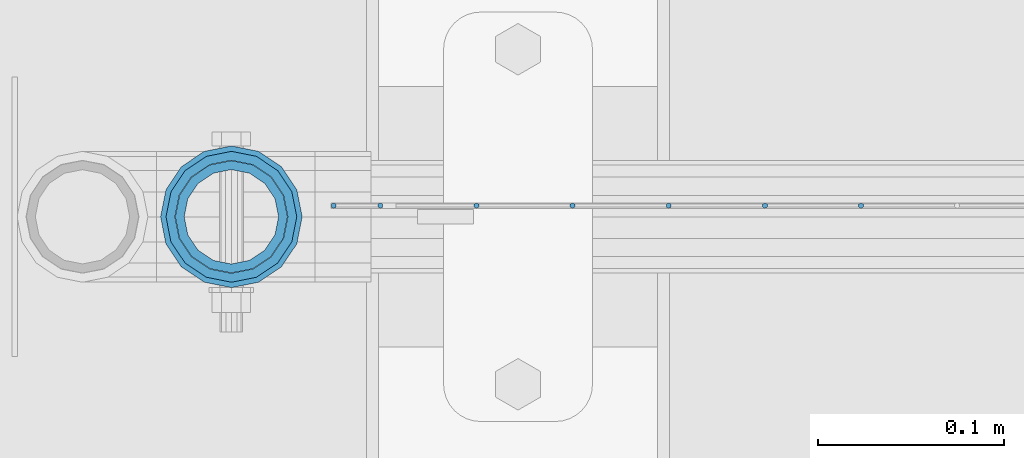
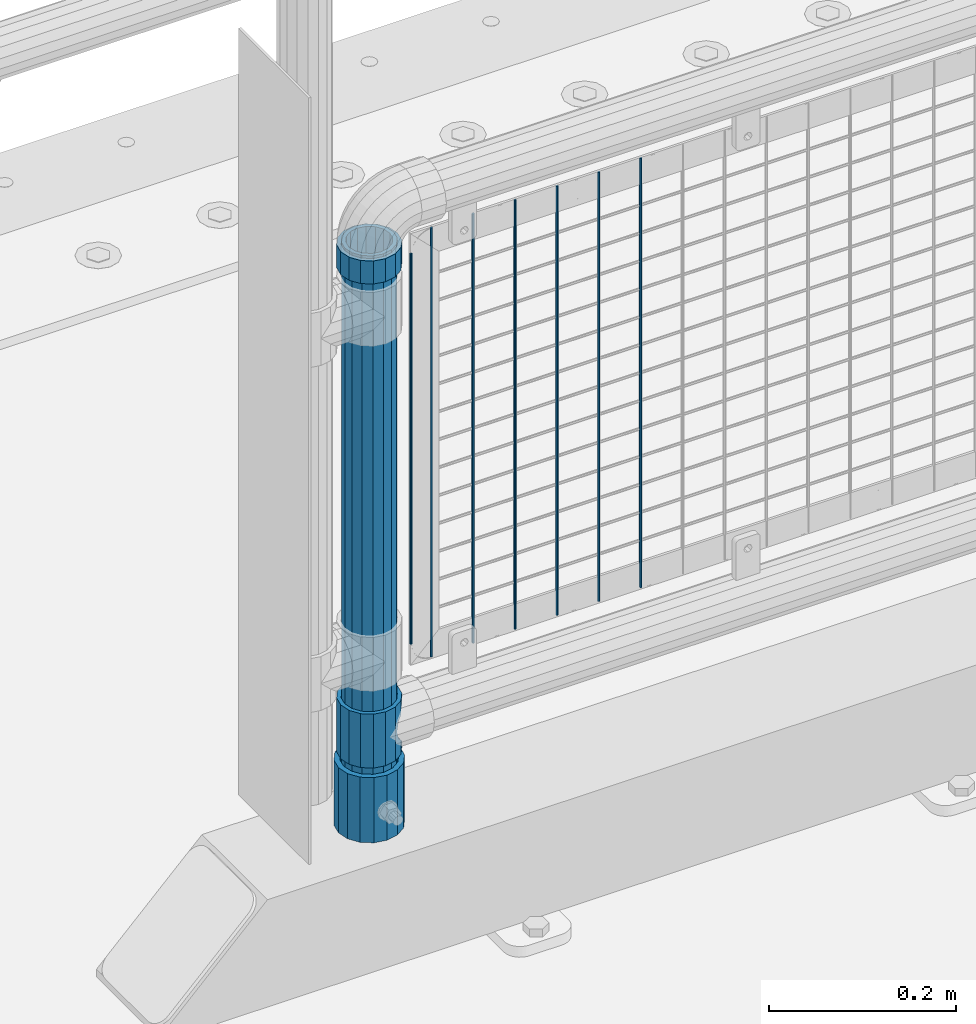
# One storey, part 63 of 219: 11 columns.
"""IFC2X3 building model written with IfcOpenShell, lengths in millimetres."""

from ifc_helpers import new_model, si_unit, frame, origin_with_axes, place, context, subcontext, project, spatial, faceted_brep, material, type_object, element, save


model = new_model("IFC2X3")

# Units and contexts
model_context = context("Model", 3, precision=1e-05, world=origin_with_axes())
body_context = subcontext(model_context, "Body", "Model", "MODEL_VIEW")
ifc_project = project(units=[si_unit("LENGTHUNIT", "METRE", prefix="MILLI"), si_unit("AREAUNIT", "SQUARE_METRE"), si_unit("VOLUMEUNIT", "CUBIC_METRE"), si_unit("MASSUNIT", "GRAM", prefix="KILO"), si_unit("TIMEUNIT", "SECOND"), si_unit("PLANEANGLEUNIT", "RADIAN"), si_unit("SOLIDANGLEUNIT", "STERADIAN"), si_unit("THERMODYNAMICTEMPERATUREUNIT", "DEGREE_CELSIUS"), si_unit("LUMINOUSINTENSITYUNIT", "LUMEN")], contexts=[model_context])

# Site, building, storey
site_placement = place(None, origin_with_axes())
site = spatial("IfcSite", under=ifc_project, at=site_placement, CompositionType="ELEMENT")
building_placement = place(site_placement, origin_with_axes())
building = spatial("IfcBuilding", under=site, at=building_placement, Name="Standard", CompositionType="ELEMENT")
storey_placement = place(building_placement, origin_with_axes())
storey = spatial("IfcBuildingStorey", under=building, at=storey_placement, Name="Undefined", CompositionType="ELEMENT", Elevation=0.0)

# Columns
ifc_material_1 = material(Name="Misc_Undefined")
column_type_1 = type_object("IfcColumnType", PredefinedType="NOTDEFINED")
column_1_placement = place(storey_placement, frame((621.0, 31664.5, 263.52), z_axis=(-1.0, 0.0, 0.0), x_axis=(0.0, 0.0, 1.0)))
element("IfcColumn", 1, at=column_1_placement, inside=storey, type_object=column_type_1, material=ifc_material_1, context=body_context, shape_type="Brep", body=[
    faceted_brep([(56.6106908090114, 21.46069080901, -21.4606908090118), (56.6106908090114, 21.46069080901, -27.1226768591096), (61.9623795176703, 13.4513226476338, -32.4743655677721), (63.1897438117172, 11.614442172282, -32.8397438117172), (63.1897438117172, 11.614442172282, -28.0397438117179), (46.7644421722801, 28.0397438117179, -11.6144421722802), (46.7644421722801, 28.0397438117179, -20.0882031229849), (51.5310424080006, 24.8548033587067, -24.8548033587067), (35.1499999999996, 30.35, 0.0), (35.1499999999996, 30.3499999999985, -16.6306603983739), (23.5355578277192, 28.0397438117179, -11.6144421722802), (23.5355578277192, 28.0397438117179, -20.0882031229849), (13.6893091909879, 21.46069080901, -21.4606908090118), (13.6893091909879, 21.46069080901, -27.1226768591096), (18.7689575919987, 24.8548033587067, -24.8548033587067), (7.11025618828211, 11.614442172282, -28.0397438117179), (7.11025618828211, 11.614442172282, -32.8397438117172), (8.33762048232455, 13.4513226476338, -32.4743655677721), (4.79999999999961, 0.0, -30.3500000000004), (4.79999999999961, 0.0, -35.1499999999996), (7.11025618828211, -11.614442172282, -28.0397438117179), (7.11025618828211, -11.614442172282, -32.839743811719), (13.6893091909879, -21.46069080901, -21.4606908090118), (13.6893091909879, -21.46069080901, -27.1226768591077), (8.33762048232455, -13.4513226476338, -32.4743655677721), (23.5355578277191, -28.0397438117179, -11.6144421722802), (23.5355578277191, -28.0397438117179, -20.0882031229739), (18.7689575919921, -24.8548033587067, -24.8548033587067), (35.1499999999996, -30.35, 0.0), (35.1499999999996, -30.3499999999985, -16.6306603983649), (46.7644421722801, -28.0397438117179, -11.6144421722802), (46.7644421722801, -28.0397438117179, -20.0882031229739), (56.6106908090114, -21.46069080901, -21.4606908090118), (56.6106908090114, -21.46069080901, -27.1226768591077), (51.5310424080006, -24.8548033587067, -24.8548033587067), (63.1897438117172, -11.614442172282, -28.0397438117179), (63.1897438117172, -11.614442172282, -32.839743811719), (61.9623795176747, -13.4513226476338, -32.4743655677721), (65.4999999999997, 0.0, -30.3500000000004), (65.4999999999997, 0.0, -35.1499999999996), (70.2999999999993, -11.614442172282, -28.0397438117179), (70.2999999999993, 0.0, -30.3500000000004), (70.2999999999993, -21.46069080901, -21.4606908090118), (70.2999999999993, -28.0397438117179, -11.6144421722802), (70.2999999999993, -30.3499999999985, 0.0), (0.0, -28.0397438117179, -11.6144421722802), (0.0, -30.3499999999985, 0.0), (0.0, -21.46069080901, -21.4606908090118), (0.0, -11.614442172282, -28.0397438117179), (0.0, 0.0, -30.3500000000004), (0.0, 11.614442172282, -28.0397438117179), (0.0, 21.46069080901, -21.4606908090118), (0.0, 28.0397438117179, -11.6144421722802), (0.0, 30.3499999999985, 0.0), (0.0, -24.8548033587067, -24.8548033587067), (0.0, -13.4513226476338, -32.4743655677721), (0.0, 0.0, -35.1500000000015), (0.0, 13.4513226476338, -32.4743655677721), (0.0, 24.8548033587067, -24.8548033587067), (0.0, -32.4743655677703, 13.4513226476338), (0.0, -35.1500000000015, 0.0), (70.2999999999993, -35.1500000000015, 0.0), (70.2999999999993, -32.4743655677703, 13.4513226476338), (0.0, -24.8548033587067, 24.8548033587067), (70.2999999999993, -24.8548033587067, 24.8548033587067), (0.0, -13.4513226476338, 32.4743655677721), (70.2999999999993, -13.4513226476338, 32.4743655677721), (0.0, 0.0, 35.1500000000015), (70.2999999999993, 0.0, 35.1499999999996), (0.0, 13.4513226476338, 32.4743655677721), (70.2999999999993, 13.4513226476338, 32.4743655677721), (0.0, 24.8548033587067, 24.8548033587067), (70.2999999999993, 24.8548033587067, 24.8548033587067), (0.0, 32.4743655677703, 13.4513226476338), (70.2999999999993, 32.4743655677703, 13.4513226476338), (0.0, 35.1500000000015, 0.0), (70.2999999999993, 35.1500000000015, 0.0), (0.0, 32.4743655677703, -13.4513226476338), (70.2999999999993, 32.4743655677703, -13.4513226476338), (70.2999999999993, 24.8548033587067, -24.8548033587067), (70.2999999999993, 13.4513226476338, -32.4743655677721), (70.2999999999993, 0.0, -35.1499999999996), (70.2999999999993, -13.4513226476338, -32.4743655677721), (70.2999999999993, -24.8548033587067, -24.8548033587067), (70.2999999999993, -32.4743655677703, -13.4513226476338), (0.0, -32.4743655677703, -13.4513226476338), (0.0, 28.0397438117179, 11.6144421722802), (0.0, 21.46069080901, 21.4606908090118), (0.0, 11.614442172282, 28.0397438117179), (0.0, 0.0, 30.3500000000004), (0.0, -11.614442172282, 28.0397438117179), (0.0, -21.46069080901, 21.4606908090118), (0.0, -28.0397438117179, 11.6144421722802), (70.2999999999993, 28.0397438117179, 11.6144421722802), (70.2999999999993, 21.46069080901, 21.4606908090118), (70.2999999999993, 11.614442172282, 28.0397438117179), (70.2999999999993, 0.0, 30.3500000000004), (70.2999999999993, -11.614442172282, 28.0397438117179), (70.2999999999993, -21.46069080901, 21.4606908090118), (70.2999999999993, -28.0397438117179, 11.6144421722802), (70.2999999999993, 30.3499999999985, 0.0), (70.2999999999993, 28.0397438117179, -11.6144421722802), (70.2999999999993, 21.46069080901, -21.4606908090118), (70.2999999999993, 11.614442172282, -28.0397438117179)], [[[0, 1, 2, 3, 4]], [[5, 6, 7, 1, 0]], [[8, 9, 6, 5]], [[10, 11, 9, 8]], [[12, 13, 14, 11, 10]], [[15, 16, 17, 13, 12]], [[18, 19, 16, 15]], [[20, 21, 19, 18]], [[22, 23, 24, 21, 20]], [[25, 26, 27, 23, 22]], [[28, 29, 26, 25]], [[30, 31, 29, 28]], [[32, 33, 34, 31, 30]], [[35, 36, 37, 33, 32]], [[38, 39, 36, 35]], [[4, 3, 39, 38]], [[40, 41, 38, 35]], [[42, 40, 35, 32]], [[43, 42, 32, 30]], [[44, 43, 30, 28]], [[45, 46, 28, 25]], [[47, 45, 25, 22]], [[48, 47, 22, 20]], [[49, 48, 20, 18]], [[50, 49, 18, 15]], [[51, 50, 15, 12]], [[52, 51, 12, 10]], [[53, 52, 10, 8]], [[54, 55, 24, 23, 27]], [[55, 56, 19, 21, 24]], [[19, 56, 57, 17, 16]], [[17, 57, 58, 14, 13]], [[59, 60, 61, 62]], [[63, 59, 62, 64]], [[65, 63, 64, 66]], [[67, 65, 66, 68]], [[69, 67, 68, 70]], [[71, 69, 70, 72]], [[73, 71, 72, 74]], [[75, 73, 74, 76]], [[77, 75, 76, 78]], [[14, 58, 77, 78, 79, 7, 6, 9, 11]], [[79, 80, 2, 1, 7]], [[80, 81, 39, 3, 2]], [[37, 82, 83, 34, 33]], [[39, 81, 82, 37, 36]], [[34, 83, 84, 85, 54, 27, 26, 29, 31]], [[60, 85, 84, 61]], [[59, 63, 65, 67, 69, 71, 73, 75, 77, 58, 57, 56, 55, 54, 85, 60], [45, 47, 48, 49, 50, 51, 52, 53, 86, 87, 88, 89, 90, 91, 92, 46]], [[87, 86, 93, 94]], [[88, 87, 94, 95]], [[89, 88, 95, 96]], [[90, 89, 96, 97]], [[91, 90, 97, 98]], [[92, 91, 98, 99]], [[28, 46, 92, 99, 44]], [[83, 82, 81, 80, 79, 78, 76, 74, 72, 70, 68, 66, 64, 62, 61, 84], [98, 97, 96, 95, 94, 93, 100, 101, 102, 103, 41, 40, 42, 43, 44, 99]], [[86, 53, 8, 100, 93]], [[101, 100, 8, 5]], [[102, 101, 5, 0]], [[103, 102, 0, 4]], [[41, 103, 4, 38]]]),
])
column_2_placement = place(storey_placement, frame((621.0, 31664.5, 894.849999999999), z_axis=(-1.0, 0.0, 0.0), x_axis=(0.0, 0.0, 1.0)))
element("IfcColumn", 2, at=column_2_placement, inside=storey, type_object=column_type_1, material=ifc_material_1, context=body_context, shape_type="Brep", body=[
    faceted_brep([(0.0, -30.3499999999985, 0.0), (0.0, -28.0397438117179, 11.6144421722802), (30.0, -28.0397438117179, 11.6144421722805), (30.0, -30.3499999999985, 0.0), (0.0, -21.46069080901, 21.4606908090118), (30.0, -21.46069080901, 21.4606908090117), (0.0, -11.614442172282, 28.0397438117179), (30.0, -11.614442172282, 28.0397438117176), (0.0, 0.0, 30.3500000000004), (30.0, 0.0, 30.35), (0.0, 11.614442172282, 28.0397438117179), (30.0, 11.614442172282, 28.0397438117176), (0.0, 21.46069080901, 21.4606908090118), (30.0, 21.46069080901, 21.4606908090117), (0.0, 28.0397438117179, 11.6144421722802), (30.0, 28.0397438117179, 11.6144421722805), (0.0, 30.3499999999985, 0.0), (30.0, 30.3499999999985, 0.0), (0.0, 28.0397438117179, -11.6144421722802), (30.0, 28.0397438117179, -11.6144421722805), (0.0, 21.46069080901, -21.4606908090118), (30.0, 21.46069080901, -21.4606908090117), (0.0, 11.614442172282, -28.0397438117179), (30.0, 11.614442172282, -28.0397438117176), (0.0, 0.0, -30.3500000000004), (30.0, 0.0, -30.35), (0.0, -11.614442172282, -28.0397438117179), (30.0, -11.614442172282, -28.0397438117176), (0.0, -21.46069080901, -21.4606908090118), (30.0, -21.46069080901, -21.4606908090117), (0.0, -28.0397438117179, -11.6144421722802), (30.0, -28.0397438117179, -11.6144421722805), (0.0, -35.1500000000015, 0.0), (0.0, -32.4743655677703, -13.4513226476338), (30.0, -32.4743655677703, -13.4513226476329), (30.0, -35.1500000000015, 0.0), (0.0, -24.8548033587067, -24.8548033587067), (30.0, -24.8548033587067, -24.8548033587072), (0.0, -13.4513226476338, -32.4743655677721), (30.0, -13.4513226476338, -32.4743655677718), (0.0, 0.0, -35.1500000000015), (30.0, 0.0, -35.15), (0.0, 13.4513226476338, -32.4743655677721), (30.0, 13.4513226476338, -32.4743655677718), (0.0, 24.8548033587067, -24.8548033587067), (30.0, 24.8548033587067, -24.8548033587072), (0.0, 32.4743655677703, -13.4513226476338), (30.0, 32.4743655677703, -13.4513226476329), (0.0, 35.1500000000015, 0.0), (30.0, 35.1500000000015, 0.0), (0.0, 32.4743655677703, 13.4513226476338), (30.0, 32.4743655677703, 13.4513226476329), (0.0, 24.8548033587067, 24.8548033587067), (30.0, 24.8548033587067, 24.8548033587072), (0.0, 13.4513226476338, 32.4743655677721), (30.0, 13.4513226476338, 32.4743655677718), (0.0, 0.0, 35.1500000000015), (30.0, 0.0, 35.15), (0.0, -13.4513226476338, 32.4743655677721), (30.0, -13.4513226476338, 32.4743655677718), (0.0, -24.8548033587067, 24.8548033587067), (30.0, -24.8548033587067, 24.8548033587072), (0.0, -32.4743655677703, 13.4513226476338), (30.0, -32.4743655677703, 13.4513226476329)], [[[0, 1, 2, 3]], [[1, 4, 5, 2]], [[4, 6, 7, 5]], [[6, 8, 9, 7]], [[8, 10, 11, 9]], [[10, 12, 13, 11]], [[12, 14, 15, 13]], [[14, 16, 17, 15]], [[16, 18, 19, 17]], [[18, 20, 21, 19]], [[20, 22, 23, 21]], [[22, 24, 25, 23]], [[24, 26, 27, 25]], [[26, 28, 29, 27]], [[28, 30, 31, 29]], [[30, 0, 3, 31]], [[32, 33, 34, 35]], [[33, 36, 37, 34]], [[36, 38, 39, 37]], [[38, 40, 41, 39]], [[40, 42, 43, 41]], [[42, 44, 45, 43]], [[44, 46, 47, 45]], [[46, 48, 49, 47]], [[48, 50, 51, 49]], [[50, 52, 53, 51]], [[52, 54, 55, 53]], [[54, 56, 57, 55]], [[56, 58, 59, 57]], [[58, 60, 61, 59]], [[60, 62, 63, 61]], [[62, 32, 35, 63]], [[37, 39, 41, 43, 45, 47, 49, 51, 53, 55, 57, 59, 61, 63, 35, 34], [5, 7, 9, 11, 13, 15, 17, 19, 21, 23, 25, 27, 29, 31, 3, 2]], [[62, 60, 58, 56, 54, 52, 50, 48, 46, 44, 42, 40, 38, 36, 33, 32], [30, 28, 26, 24, 22, 20, 18, 16, 14, 12, 10, 8, 6, 4, 1, 0]]]),
])
ifc_material_2 = material()
column_type_2 = type_object("IfcColumnType", PredefinedType="NOTDEFINED")
column_3_placement = place(storey_placement, frame((620.999999804207, 31664.5, 168.019999999998), z_axis=(-1.0, 0.0, 0.0), x_axis=(0.0, 0.0, 1.0)))
element("IfcColumn", 3, at=column_3_placement, inside=storey, type_object=column_type_2, material=ifc_material_2, context=body_context, shape_type="Brep", body=[
    faceted_brep([(0.0, -25.3499999999985, 0.0), (0.0, -23.4203461491597, 9.70102501045585), (760.0, -23.4203461491597, 9.70102501045585), (760.0, -25.3499999999985, 0.0), (0.0, -17.9251569030785, 17.9251569030785), (760.0, -17.9251569030785, 17.9251569030785), (0.0, -9.70102501045403, 23.4203461491616), (760.0, -9.70102501045403, 23.4203461491616), (0.0, 0.0, 25.3500000000004), (760.0, 0.0, 25.3500000000004), (0.0, 9.70102501045403, 23.4203461491616), (760.0, 9.70102501045403, 23.4203461491616), (0.0, 17.9251569030785, 17.9251569030785), (760.0, 17.9251569030785, 17.9251569030785), (0.0, 23.4203461491597, 9.70102501045585), (760.0, 23.4203461491597, 9.70102501045585), (0.0, 25.3499999999985, 0.0), (760.0, 25.3499999999985, 0.0), (0.0, 23.4203461491597, -9.70102501045585), (760.0, 23.4203461491597, -9.70102501045585), (0.0, 17.9251569030785, -17.9251569030785), (760.0, 17.9251569030785, -17.9251569030785), (0.0, 9.70102501045403, -23.4203461491616), (760.0, 9.70102501045403, -23.4203461491616), (0.0, 0.0, -25.3500000000004), (760.0, 0.0, -25.3500000000004), (0.0, -9.70102501045403, -23.4203461491616), (760.0, -9.70102501045403, -23.4203461491616), (0.0, -17.9251569030785, -17.9251569030785), (760.0, -17.9251569030785, -17.9251569030785), (0.0, -23.4203461491597, -9.70102501045585), (760.0, -23.4203461491597, -9.70102501045585), (0.0, -30.1500000000015, 0.0), (0.0, -27.8549679052157, -11.5379054858076), (760.0, -27.8549679052157, -11.5379054858076), (760.0, -30.1500000000015, 0.0), (0.0, -21.3192694527752, -21.3192694527752), (760.0, -21.3192694527752, -21.3192694527752), (0.0, -11.5379054858058, -27.8549679052157), (760.0, -11.5379054858058, -27.8549679052157), (0.0, 0.0, -30.1499999999996), (760.0, 0.0, -30.1499999999996), (0.0, 11.5379054858058, -27.8549679052157), (760.0, 11.5379054858058, -27.8549679052157), (0.0, 21.3192694527752, -21.3192694527752), (760.0, 21.3192694527752, -21.3192694527752), (0.0, 27.8549679052157, -11.5379054858076), (760.0, 27.8549679052157, -11.5379054858076), (0.0, 30.1500000000015, 0.0), (760.0, 30.1500000000015, 0.0), (0.0, 27.8549679052157, 11.5379054858076), (760.0, 27.8549679052157, 11.5379054858076), (0.0, 21.3192694527752, 21.3192694527752), (760.0, 21.3192694527752, 21.3192694527752), (0.0, 11.5379054858058, 27.8549679052157), (760.0, 11.5379054858058, 27.8549679052157), (0.0, 0.0, 30.1499999999996), (760.0, 0.0, 30.1499999999996), (0.0, -11.5379054858058, 27.8549679052157), (760.0, -11.5379054858058, 27.8549679052157), (0.0, -21.3192694527752, 21.3192694527752), (760.0, -21.3192694527752, 21.3192694527752), (0.0, -27.8549679052157, 11.5379054858076), (760.0, -27.8549679052157, 11.5379054858076)], [[[0, 1, 2, 3]], [[1, 4, 5, 2]], [[4, 6, 7, 5]], [[6, 8, 9, 7]], [[8, 10, 11, 9]], [[10, 12, 13, 11]], [[12, 14, 15, 13]], [[14, 16, 17, 15]], [[16, 18, 19, 17]], [[18, 20, 21, 19]], [[20, 22, 23, 21]], [[22, 24, 25, 23]], [[24, 26, 27, 25]], [[26, 28, 29, 27]], [[28, 30, 31, 29]], [[30, 0, 3, 31]], [[32, 33, 34, 35]], [[33, 36, 37, 34]], [[36, 38, 39, 37]], [[38, 40, 41, 39]], [[40, 42, 43, 41]], [[42, 44, 45, 43]], [[44, 46, 47, 45]], [[46, 48, 49, 47]], [[48, 50, 51, 49]], [[50, 52, 53, 51]], [[52, 54, 55, 53]], [[54, 56, 57, 55]], [[56, 58, 59, 57]], [[58, 60, 61, 59]], [[60, 62, 63, 61]], [[62, 32, 35, 63]], [[37, 39, 41, 43, 45, 47, 49, 51, 53, 55, 57, 59, 61, 63, 35, 34], [5, 7, 9, 11, 13, 15, 17, 19, 21, 23, 25, 27, 29, 31, 3, 2]], [[62, 60, 58, 56, 54, 52, 50, 48, 46, 44, 42, 40, 38, 36, 33, 32], [30, 28, 26, 24, 22, 20, 18, 16, 14, 12, 10, 8, 6, 4, 1, 0]]]),
])
column_type_3 = type_object("IfcColumnType", PredefinedType="NOTDEFINED")
column_4_placement = place(storey_placement, frame((620.999999804207, 31664.5, 168.019999999998), z_axis=(0.0, 1.0, 0.0), x_axis=(0.0, 0.0, 1.0)))
element("IfcColumn", 4, at=column_4_placement, inside=storey, type_object=column_type_3, material=ifc_material_2, context=body_context, shape_type="Brep", body=[
    faceted_brep([(0.0, -31.75, 0.0), (0.0, -29.3331751572332, 12.1501989775934), (85.0, -29.3331751572332, 12.1501989775934), (85.0, -31.75, 0.0), (0.0, -22.4506403026735, 22.4506403026717), (85.0, -22.4506403026735, 22.4506403026717), (0.0, -12.1501989775916, 29.3331751572332), (85.0, -12.1501989775916, 29.3331751572332), (0.0, 0.0, 31.75), (85.0, 0.0, 31.75), (0.0, 12.1501989775916, 29.3331751572332), (85.0, 12.1501989775916, 29.3331751572332), (0.0, 22.4506403026735, 22.4506403026717), (85.0, 22.4506403026735, 22.4506403026717), (0.0, 29.3331751572332, 12.1501989775934), (85.0, 29.3331751572332, 12.1501989775934), (0.0, 31.75, 0.0), (85.0, 31.75, 0.0), (0.0, 29.3331751572332, -12.1501989775934), (85.0, 29.3331751572332, -12.1501989775934), (0.0, 22.4506403026735, -22.4506403026717), (85.0, 22.4506403026735, -22.4506403026717), (0.0, 12.1501989775916, -29.3331751572332), (85.0, 12.1501989775916, -29.3331751572332), (0.0, 0.0, -31.75), (85.0, 0.0, -31.75), (0.0, -12.1501989775916, -29.3331751572332), (85.0, -12.1501989775916, -29.3331751572332), (0.0, -22.4506403026735, -22.4506403026717), (85.0, -22.4506403026735, -22.4506403026717), (0.0, -29.3331751572332, -12.1501989775934), (85.0, -29.3331751572332, -12.1501989775934), (0.0, -38.0499999999993, 0.0), (0.0, -35.1536162120537, -14.5611046014928), (85.0, -35.1536162120537, -14.5611046014928), (85.0, -38.0499999999993, 0.0), (0.0, -26.9054130241475, -26.9054130241493), (85.0, -26.9054130241475, -26.9054130241493), (0.0, -14.561104601491, -35.1536162120537), (85.0, -14.561104601491, -35.1536162120537), (0.0, 0.0, -38.0499999999993), (85.0, 0.0, -38.0499999999993), (0.0, 14.561104601491, -35.1536162120537), (85.0, 14.561104601491, -35.1536162120537), (0.0, 26.9054130241475, -26.9054130241493), (85.0, 26.9054130241475, -26.9054130241493), (0.0, 35.1536162120537, -14.5611046014928), (85.0, 35.1536162120537, -14.5611046014928), (0.0, 38.0499999999993, 0.0), (85.0, 38.0499999999993, 0.0), (0.0, 35.1536162120537, 14.5611046014928), (85.0, 35.1536162120537, 14.5611046014928), (0.0, 26.9054130241475, 26.9054130241493), (85.0, 26.9054130241475, 26.9054130241493), (0.0, 14.561104601491, 35.1536162120537), (85.0, 14.561104601491, 35.1536162120537), (0.0, 0.0, 38.0499999999993), (85.0, 0.0, 38.0499999999993), (0.0, -14.561104601491, 35.1536162120537), (85.0, -14.561104601491, 35.1536162120537), (0.0, -26.9054130241475, 26.9054130241493), (85.0, -26.9054130241475, 26.9054130241493), (0.0, -35.1536162120537, 14.5611046014928), (85.0, -35.1536162120537, 14.5611046014928)], [[[0, 1, 2, 3]], [[1, 4, 5, 2]], [[4, 6, 7, 5]], [[6, 8, 9, 7]], [[8, 10, 11, 9]], [[10, 12, 13, 11]], [[12, 14, 15, 13]], [[14, 16, 17, 15]], [[16, 18, 19, 17]], [[18, 20, 21, 19]], [[20, 22, 23, 21]], [[22, 24, 25, 23]], [[24, 26, 27, 25]], [[26, 28, 29, 27]], [[28, 30, 31, 29]], [[30, 0, 3, 31]], [[32, 33, 34, 35]], [[33, 36, 37, 34]], [[36, 38, 39, 37]], [[38, 40, 41, 39]], [[40, 42, 43, 41]], [[42, 44, 45, 43]], [[44, 46, 47, 45]], [[46, 48, 49, 47]], [[48, 50, 51, 49]], [[50, 52, 53, 51]], [[52, 54, 55, 53]], [[54, 56, 57, 55]], [[56, 58, 59, 57]], [[58, 60, 61, 59]], [[60, 62, 63, 61]], [[62, 32, 35, 63]], [[37, 39, 41, 43, 45, 47, 49, 51, 53, 55, 57, 59, 61, 63, 35, 34], [5, 7, 9, 11, 13, 15, 17, 19, 21, 23, 25, 27, 29, 31, 3, 2]], [[62, 60, 58, 56, 54, 52, 50, 48, 46, 44, 42, 40, 38, 36, 33, 32], [30, 28, 26, 24, 22, 20, 18, 16, 14, 12, 10, 8, 6, 4, 1, 0]]]),
])
column_type_4 = type_object("IfcColumnType", Name="D3", PredefinedType="NOTDEFINED")
for number, where, z_axis, x_axis in (
    (5, (959.275000000001, 31670.5, 353.02), (-1.0, 0.0, 0.0), (0.0, 0.0, 1.0)),
    (6, (907.620000000003, 31670.5, 353.02), (-1.0, 0.0, 0.0), (0.0, 0.0, 1.0)),
    (7, (855.964999999997, 31670.5, 353.02), (-1.0, 0.0, 0.0), (0.0, 0.0, 1.0)),
    (8, (804.309999999998, 31670.5, 353.02), (-1.0, 0.0, 0.0), (0.0, 0.0, 1.0)),
    (9, (752.654999999999, 31670.5, 353.02), (-1.0, 0.0, 0.0), (0.0, 0.0, 1.0)),
):
    element("IfcColumn", number, at=place(storey_placement, frame(where, z_axis=z_axis, x_axis=x_axis)), inside=storey, type_object=column_type_4, material=ifc_material_1, ObjectType="D3", context=body_context, shape_type="Brep", body=[
        faceted_brep([(0.0, -1.5, -5.6843418860808e-14), (0.0, -0.75, -1.29903810567669), (560.0, -0.75, -1.29903810567703), (560.0, -1.5, 0.0), (0.0, 0.75, -1.29903810567669), (560.0, 0.75, -1.29903810567703), (0.0, 1.5, -5.6843418860808e-14), (560.0, 1.5, 0.0), (0.0, 0.75, 1.29903810567669), (560.0, 0.75, 1.29903810567703), (0.0, -0.75, 1.29903810567669), (560.0, -0.75, 1.29903810567703)], [[[0, 1, 2, 3]], [[1, 4, 5, 2]], [[4, 6, 7, 5]], [[6, 8, 9, 7]], [[8, 10, 11, 9]], [[10, 0, 3, 11]], [[5, 7, 9, 11, 3, 2]], [[10, 8, 6, 4, 1, 0]]]),
    ])
column_5_placement = place(storey_placement, frame((676.0, 31670.5, 378.02), z_axis=(-1.0, 0.0, 0.0), x_axis=(0.0, 0.0, 1.0)))
element("IfcColumn", 10, at=column_5_placement, inside=storey, type_object=column_type_4, material=ifc_material_1, ObjectType="D3", context=body_context, shape_type="Brep", body=[
    faceted_brep([(0.0, -1.5, -5.6843418860808e-14), (0.0, -0.75, -1.29903810567669), (510.0, -0.75, -1.29903810567703), (510.0, -1.5, 0.0), (0.0, 0.75, -1.29903810567669), (510.0, 0.75, -1.29903810567703), (0.0, 1.5, -5.6843418860808e-14), (510.0, 1.5, 0.0), (0.0, 0.75, 1.29903810567669), (510.0, 0.75, 1.29903810567703), (0.0, -0.75, 1.29903810567669), (510.0, -0.75, 1.29903810567703)], [[[0, 1, 2, 3]], [[1, 4, 5, 2]], [[4, 6, 7, 5]], [[6, 8, 9, 7]], [[8, 10, 11, 9]], [[10, 0, 3, 11]], [[5, 7, 9, 11, 3, 2]], [[10, 8, 6, 4, 1, 0]]]),
])
column_6_placement = place(storey_placement, frame((701.0, 31670.5, 353.02), z_axis=(-1.0, 0.0, 0.0), x_axis=(0.0, 0.0, 1.0)))
element("IfcColumn", 11, at=column_6_placement, inside=storey, type_object=column_type_4, material=ifc_material_1, ObjectType="D3", context=body_context, shape_type="Brep", body=[
    faceted_brep([(0.0, -1.5, -5.6843418860808e-14), (0.0, -0.75, -1.29903810567669), (560.0, -0.75, -1.29903810567703), (560.0, -1.5, 0.0), (0.0, 0.75, -1.29903810567669), (560.0, 0.75, -1.29903810567703), (0.0, 1.5, -5.6843418860808e-14), (560.0, 1.5, 0.0), (0.0, 0.75, 1.29903810567669), (560.0, 0.75, 1.29903810567703), (0.0, -0.75, 1.29903810567669), (560.0, -0.75, 1.29903810567703)], [[[0, 1, 2, 3]], [[1, 4, 5, 2]], [[4, 6, 7, 5]], [[6, 8, 9, 7]], [[8, 10, 11, 9]], [[10, 0, 3, 11]], [[5, 7, 9, 11, 3, 2]], [[10, 8, 6, 4, 1, 0]]]),
])

save(model, "model.ifc")
